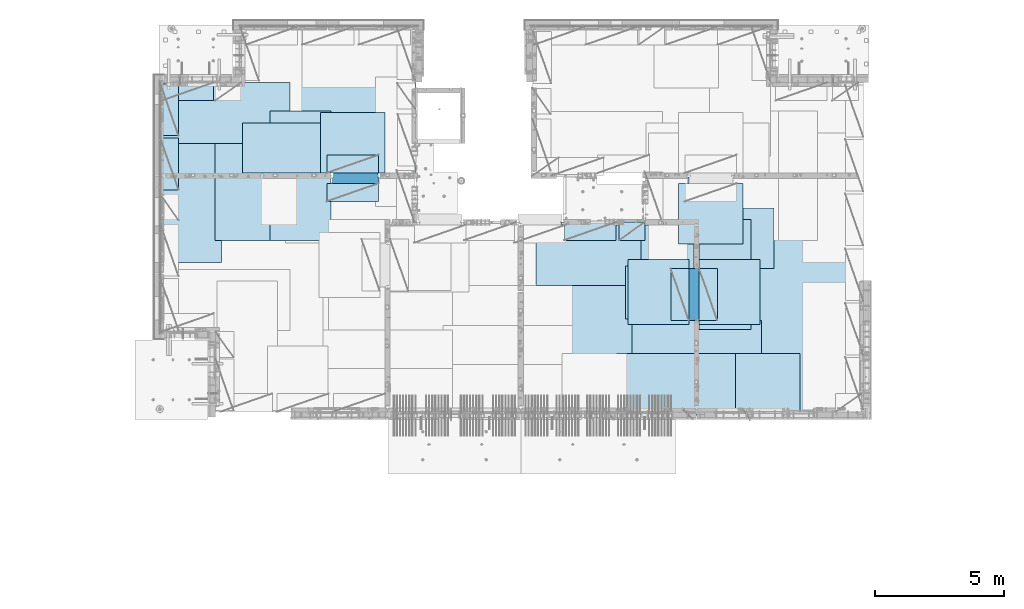
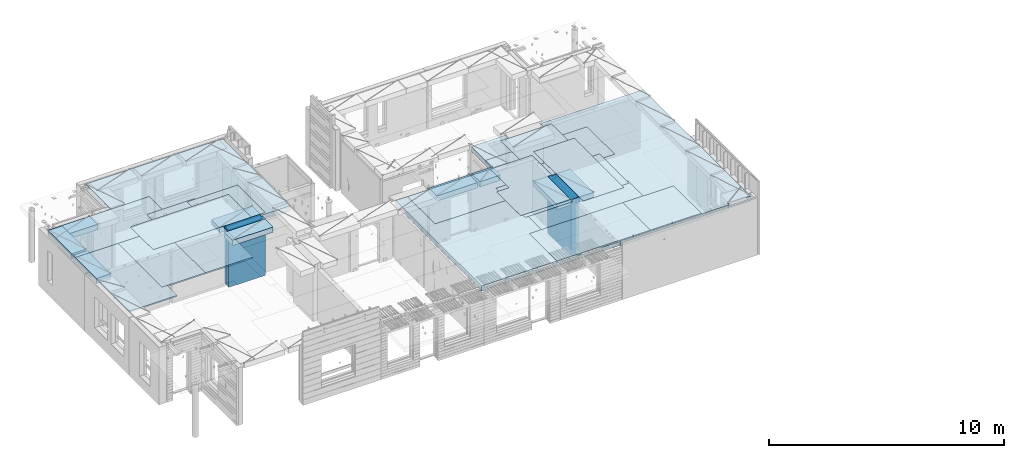
# One storey, part 175 of 309: 27 plates, 3 slabs, 25 elements without a shape of their own.
"""IFC2X3 building model written with IfcOpenShell, lengths in millimetres."""

from ifc_helpers import new_model, si_unit, frame, origin_with_axes, place, context, subcontext, project, spatial, faceted_brep, material, type_object, element, aggregate, save


model = new_model("IFC2X3")

# Units and contexts
model_context = context("Model", 3, precision=1e-05, world=origin_with_axes())
body_context = subcontext(model_context, "Body", "Model", "MODEL_VIEW")
ifc_project = project(units=[si_unit("LENGTHUNIT", "METRE", prefix="MILLI"), si_unit("AREAUNIT", "SQUARE_METRE"), si_unit("VOLUMEUNIT", "CUBIC_METRE"), si_unit("MASSUNIT", "GRAM", prefix="KILO"), si_unit("TIMEUNIT", "SECOND"), si_unit("PLANEANGLEUNIT", "RADIAN"), si_unit("SOLIDANGLEUNIT", "STERADIAN"), si_unit("THERMODYNAMICTEMPERATUREUNIT", "DEGREE_CELSIUS"), si_unit("LUMINOUSINTENSITYUNIT", "LUMEN")], contexts=[model_context])

# Site, building, storey
site_placement = place(None, origin_with_axes())
site = spatial("IfcSite", under=ifc_project, at=site_placement, CompositionType="ELEMENT")
building_placement = place(site_placement, origin_with_axes())
building = spatial("IfcBuilding", under=site, at=building_placement, CompositionType="ELEMENT")
storey_placement = place(building_placement, origin_with_axes())
storey = spatial("IfcBuildingStorey", under=building, at=storey_placement, Name="7", CompositionType="ELEMENT", Elevation=0.0)

# Assembly, slabs
assembly_1_placement = place(storey_placement, origin_with_axes())
assembly_1 = element("IfcElementAssembly", 1, at=assembly_1_placement, inside=storey, AssemblyPlace="NOTDEFINED", PredefinedType="REINFORCEMENT_UNIT")
ifc_material_1 = material(Name="CONCRETE/C30/37")
slab_type_1 = type_object("IfcSlabType", PredefinedType="NOTDEFINED")
slab_1_placement = place(assembly_1_placement, frame((21810.0, 7750.0, 102595.0), z_axis=(0.0, 1.0, 0.0), x_axis=(1.0, 0.0, 0.0)))
slab_1 = element("IfcSlab", 2, at=slab_1_placement, type_object=slab_type_1, material=ifc_material_1, PredefinedType="FLOOR", context=body_context, shape_type="Brep", body=[
    faceted_brep([(6500.0, -135.0, 5637.99963378906), (6500.0, 135.0, 5637.99963378906), (6500.0, 135.0, 5680.0), (6500.0, -135.0, 5680.0), (6800.0, -135.0, 5680.0), (6800.0, 135.0, 5680.0), (6800.0, -135.0, 3637.99963378906), (6800.0, 135.0, 3637.99963378906), (6500.0, 135.0, 3637.99963378906), (6500.0, -135.0, 3637.99963378906), (6800.0, -135.0, 0.0), (6800.0, 135.0, 0.0), (1.81898940354586e-12, -135.0, 1.81898940354586e-12), (1.81898940354586e-12, 135.0, 1.81898940354586e-12), (0.0, -135.0, 7330.0), (0.0, 135.0, 7330.0), (1569.99914550782, -135.0, 7330.0), (1569.99914550782, 135.0, 7330.0), (1569.99914550782, -135.0, 7430.0), (1569.99914550782, 135.0, 7430.0), (6800.0, -135.0, 7430.0), (6800.0, 135.0, 7430.0), (6500.0, 135.0, 3780.0), (6500.0, -135.0, 3780.0)], [[[0, 1, 2, 3]], [[4, 3, 2, 5]], [[6, 7, 8, 9]], [[10, 11, 7, 6]], [[10, 12, 13, 11]], [[12, 14, 15, 13]], [[16, 17, 15, 14]], [[18, 19, 17, 16]], [[20, 21, 19, 18]], [[21, 20, 4, 5]], [[1, 22, 8, 7, 11, 13, 15, 17, 19, 21, 5, 2]], [[23, 9, 8, 22, 1, 0]], [[20, 18, 16, 14, 12, 10, 6, 9, 23, 0, 3, 4]]]),
])
slab_type_2 = type_object("IfcSlabType", PredefinedType="NOTDEFINED")
slab_2_placement = place(assembly_1_placement, frame((7880.0, 16980.0, 102595.0), z_axis=(0.0, 1.0, 0.0), x_axis=(1.0, 0.0, 0.0)))
slab_2 = element("IfcSlab", 3, at=slab_2_placement, type_object=slab_type_2, material=ifc_material_1, PredefinedType="FLOOR", context=body_context, shape_type="Brep", body=[
    faceted_brep([(6583.68914550781, -135.0, 0.0), (6583.68914550781, 135.0, 0.0), (6583.68914550781, 135.0, 100.0), (6583.68914550781, -135.0, 100.0), (6649.99914550781, -135.0, 99.9997787475586), (6649.99914550781, 135.0, 99.9997787475586), (1.81898940354586e-12, -135.0, 1.81898940354586e-12), (-0.0001220703125, -135.0, 3600.0), (-0.0001220703125, 135.0, 3600.0), (1.81898940354586e-12, 135.0, 1.81898940354586e-12), (3110.00024414063, -135.0, 3600.0), (3110.00024414063, 135.0, 3600.0), (3110.00024414063, -135.0, 5760.0), (3110.00024414063, 135.0, 5760.0), (9850.0009765625, -135.0, 5760.0), (9850.0009765625, 135.0, 5760.0), (9850.0009765625, -135.0, 3600.0), (9850.0009765625, 135.0, 3600.0), (9870.0, -135.0, 3600.0), (9870.0, 135.0, 3600.0), (9870.0, -135.0, 0.0), (9870.0, 135.0, 0.0), (8449.99914550781, -135.0, 0.0), (8449.99914550781, 135.0, 0.0), (8449.99914550781, -135.0, 99.9997787475586), (8449.99914550781, 135.0, 99.9997787475586), (8283.68914550781, -135.0, 99.9997787475586), (8283.68914550781, 135.0, 99.9997787475586)], [[[0, 1, 2, 3]], [[4, 3, 2, 5]], [[6, 7, 8, 9]], [[7, 10, 11, 8]], [[10, 12, 13, 11]], [[12, 14, 15, 13]], [[14, 16, 17, 15]], [[16, 18, 19, 17]], [[18, 20, 21, 19]], [[21, 20, 22, 23]], [[24, 25, 23, 22]], [[26, 4, 5, 27, 25, 24]], [[1, 9, 8, 11, 13, 15, 17, 19, 21, 23, 25, 27, 5, 2]], [[6, 9, 1, 0]], [[26, 24, 22, 20, 18, 16, 14, 12, 10, 7, 6, 0, 3, 4]]]),
])
slab_type_3 = type_object("IfcSlabType", PredefinedType="NOTDEFINED")
slab_3_placement = place(assembly_1_placement, frame((28610.0, 7708.0, 102595.0), z_axis=(0.0, 1.0, 0.0), x_axis=(1.0, 0.0, 0.0)))
slab_3 = element("IfcSlab", 4, at=slab_3_placement, type_object=slab_type_3, material=ifc_material_1, PredefinedType="FLOOR", context=body_context, shape_type="Brep", body=[
    faceted_brep([(0.0, -135.0, 7430.0), (0.0, 135.0, 7430.0), (0.0, 135.0, 5722.0), (0.0, -135.0, 5722.0), (-1999.99938964844, -135.0, 7430.0), (-1999.99938964844, 135.0, 7430.0), (-1999.99938964844, -135.0, 9230.0), (-1999.99938964844, 135.0, 9230.0), (-300.000239723071, -135.0, 9230.0), (-300.000239723071, 135.0, 9230.0), (-300.00008947117, -135.0, 8972.00002930513), (-300.00008947117, 135.0, 8972.00002930513), (1385.00027673977, -135.0, 8972.00002930513), (1400.0006429507, -135.0, 8972.00002930513), (1400.0006429507, 135.0, 8972.00002930513), (1385.00027673977, 135.0, 8972.00002930513), (1400.0006429507, -135.0, 9230.0), (1400.0006429507, 135.0, 9230.0), (6449.99951171875, -135.0, 9230.0), (6449.99951171875, 135.0, 9230.0), (6449.99951171875, -135.0, 100.00023651123), (6449.99951171875, 135.0, 100.00023651123), (5318.0, -135.0, 100.0), (5318.0, 135.0, 100.0), (5318.0, -135.0, -8.68840288603678e-09), (5318.0, 135.0, -8.68840288603678e-09), (1.81898940354586e-12, -135.0, 1.81898940354586e-12), (1.81898940354586e-12, 135.0, 1.81898940354586e-12), (0.0, 135.0, 3679.99963378906), (100.00089263916, 135.0, 3679.99963378906), (100.00089263916, 135.0, 3822.0), (100.00089263916, 135.0, 5679.99963378906), (100.00089263916, 135.0, 5722.0), (100.00089263916, -135.0, 5722.0), (100.00089263916, -135.0, 3822.0), (100.00089263916, -135.0, 3679.99963378906), (0.0, -135.0, 3679.99963378906), (100.00089263916, -135.0, 5679.99963378906)], [[[0, 1, 2, 3]], [[0, 4, 5, 1]], [[4, 6, 7, 5]], [[7, 6, 8, 9]], [[8, 10, 11, 9]], [[12, 13, 14, 15, 11, 10]], [[16, 17, 14, 13]], [[18, 19, 17, 16]], [[18, 20, 21, 19]], [[20, 22, 23, 21]], [[22, 24, 25, 23]], [[24, 26, 27, 25]], [[1, 5, 7, 9, 11, 15, 14, 17, 19, 21, 23, 25, 27, 28, 29, 30, 31, 32, 2]], [[3, 2, 32, 33]], [[34, 35, 36, 26, 24, 22, 20, 18, 16, 13, 12, 10, 8, 6, 4, 0, 3, 33, 37]], [[27, 26, 36, 28]], [[35, 29, 28, 36]], [[34, 37, 31, 30, 29, 35]], [[33, 32, 31, 37]]]),
])

# Assembly, plate
assembly_2_placement = place(storey_placement, origin_with_axes())
assembly_2 = element("IfcElementAssembly", 5, at=assembly_2_placement, inside=storey, Name="Steel Assembly", AssemblyPlace="NOTDEFINED", PredefinedType="NOTDEFINED")
ifc_material_2 = material()
plate_type_1 = type_object("IfcPlateType", PredefinedType="NOTDEFINED")
plate_1_placement = place(assembly_2_placement, frame((27902.5000293051, 16680.0, 102695.1), z_axis=(1.0, 0.0, 0.0), x_axis=(0.0, -1.0, 0.0)))
plate_1 = element("IfcPlate", 6, at=plate_1_placement, type_object=plate_type_1, material=ifc_material_2, Name="1/2", context=body_context, shape_type="Brep", body=[
    faceted_brep([(0.0, -35.0, 0.0), (0.0, -35.0, 2500.0), (0.0, 35.0, 2500.0), (0.0, 35.0, 0.0), (2349.99951171875, -35.0, 2500.0), (2349.99951171875, 35.0, 2500.0), (2350.0, -35.0, 0.0), (2350.0, 35.0, 0.0)], [[[0, 1, 2, 3]], [[1, 4, 5, 2]], [[4, 6, 7, 5]], [[6, 0, 3, 7]], [[5, 7, 3, 2]], [[6, 4, 1, 0]]]),
])
aggregate(assembly_2, [plate_1])

assembly_3_placement = place(storey_placement, origin_with_axes())
assembly_3 = element("IfcElementAssembly", 7, at=assembly_3_placement, inside=storey, Name="Steel Assembly", AssemblyPlace="NOTDEFINED", PredefinedType="NOTDEFINED")
plate_2_placement = place(assembly_3_placement, frame((32610.0, 7750.0, 102695.1), z_axis=(-1.0, 3.00000001838171e-08, 0.0), x_axis=(0.0, 1.0, 0.0)))
plate_2 = element("IfcPlate", 8, at=plate_2_placement, type_object=plate_type_1, material=ifc_material_2, Name="1/2", context=body_context, shape_type="Brep", body=[
    faceted_brep([(0.0, -35.0, 0.0), (0.0, -35.0, 2500.0), (0.0, 35.0, 2500.0), (0.0, 35.0, 0.0), (2349.99951171875, -35.0, 2500.0), (2349.99951171875, 35.0, 2500.0), (2350.0, -35.0, 0.0), (2350.0, 35.0, 0.0)], [[[0, 1, 2, 3]], [[1, 4, 5, 2]], [[4, 6, 7, 5]], [[6, 0, 3, 7]], [[5, 7, 3, 2]], [[6, 4, 1, 0]]]),
])
aggregate(assembly_3, [plate_2])

assembly_4_placement = place(storey_placement, origin_with_axes())
assembly_4 = element("IfcElementAssembly", 9, at=assembly_4_placement, inside=storey, Name="Steel Assembly", AssemblyPlace="NOTDEFINED", PredefinedType="NOTDEFINED")
plate_3_placement = place(assembly_4_placement, frame((27395.0, 12730.0, 102695.1), z_axis=(-1.0, 3.00000001838171e-08, 0.0), x_axis=(0.0, 1.0, 0.0)))
plate_3 = element("IfcPlate", 10, at=plate_3_placement, type_object=plate_type_1, material=ifc_material_2, context=body_context, shape_type="Brep", body=[
    faceted_brep([(0.0, -35.0, 0.0), (0.0, -35.0, 5000.0), (0.0, 35.0, 5000.0), (0.0, 35.0, 0.0), (2349.99951171875, -35.0, 5000.0), (2349.99951171875, 35.0, 5000.0), (2350.0, -35.0, 0.0), (2350.0, 35.0, 0.0)], [[[0, 1, 2, 3]], [[1, 4, 5, 2]], [[4, 6, 7, 5]], [[6, 0, 3, 7]], [[5, 7, 3, 2]], [[6, 4, 1, 0]]]),
])
aggregate(assembly_4, [plate_3])

assembly_5_placement = place(storey_placement, origin_with_axes())
assembly_5 = element("IfcElementAssembly", 11, at=assembly_5_placement, inside=storey, Name="Steel Assembly", AssemblyPlace="NOTDEFINED", PredefinedType="NOTDEFINED")
plate_4_placement = place(assembly_5_placement, frame((28709.9995320312, 11230.0000289158, 102695.1), z_axis=(0.0, 1.0, 0.0), x_axis=(1.0, 0.0, 0.0)))
plate_4 = element("IfcPlate", 12, at=plate_4_placement, type_object=plate_type_1, material=ifc_material_2, Name="1/2", context=body_context, shape_type="Brep", body=[
    faceted_brep([(0.0, -35.0, 0.0), (0.0, -35.0, 2500.0), (0.0, 35.0, 2500.0), (0.0, 35.0, 0.0), (2349.99951171875, -35.0, 2500.0), (2349.99951171875, 35.0, 2500.0), (2350.0, -35.0, 0.0), (2350.0, 35.0, 0.0)], [[[0, 1, 2, 3]], [[1, 4, 5, 2]], [[4, 6, 7, 5]], [[6, 0, 3, 7]], [[5, 7, 3, 2]], [[6, 4, 1, 0]]]),
])
aggregate(assembly_5, [plate_4])

assembly_6_placement = place(storey_placement, origin_with_axes())
assembly_6 = element("IfcElementAssembly", 13, at=assembly_6_placement, inside=storey, Name="Steel Assembly", AssemblyPlace="NOTDEFINED", PredefinedType="NOTDEFINED")
plate_5_placement = place(assembly_6_placement, frame((25959.9995320312, 11230.0000289158, 102695.1), z_axis=(0.0, 1.0, 0.0), x_axis=(1.0, 0.0, 0.0)))
plate_5 = element("IfcPlate", 14, at=plate_5_placement, type_object=plate_type_1, material=ifc_material_2, Name="1/2", context=body_context, shape_type="Brep", body=[
    faceted_brep([(0.0, -35.0, 0.0), (0.0, -35.0, 2500.0), (0.0, 35.0, 2500.0), (0.0, 35.0, 0.0), (2349.99951171875, -35.0, 2500.0), (2349.99951171875, 35.0, 2500.0), (2350.0, -35.0, 0.0), (2350.0, 35.0, 0.0)], [[[0, 1, 2, 3]], [[1, 4, 5, 2]], [[4, 6, 7, 5]], [[6, 0, 3, 7]], [[5, 7, 3, 2]], [[6, 4, 1, 0]]]),
])
aggregate(assembly_6, [plate_5])

assembly_7_placement = place(storey_placement, origin_with_axes())
assembly_7 = element("IfcElementAssembly", 15, at=assembly_7_placement, inside=storey, Name="Steel Assembly", AssemblyPlace="NOTDEFINED", PredefinedType="NOTDEFINED")
plate_6_placement = place(assembly_7_placement, frame((7880.0, 20580.0, 102695.1), z_axis=(1.0, 0.0, 0.0), x_axis=(0.0, -1.0, 0.0)))
plate_6 = element("IfcPlate", 16, at=plate_6_placement, type_object=plate_type_1, material=ifc_material_2, context=body_context, shape_type="Brep", body=[
    faceted_brep([(0.0, -35.0, 0.0), (0.0, -35.0, 5000.0), (0.0, 35.0, 5000.0), (0.0, 35.0, 0.0), (2349.99951171875, -35.0, 5000.0), (2349.99951171875, 35.0, 5000.0), (2350.0, -35.0, 0.0), (2350.0, 35.0, 0.0)], [[[0, 1, 2, 3]], [[1, 4, 5, 2]], [[4, 6, 7, 5]], [[6, 0, 3, 7]], [[5, 7, 3, 2]], [[6, 4, 1, 0]]]),
])
aggregate(assembly_7, [plate_6])

assembly_8_placement = place(storey_placement, origin_with_axes())
assembly_8 = element("IfcElementAssembly", 17, at=assembly_8_placement, inside=storey, Name="Steel Assembly", AssemblyPlace="NOTDEFINED", PredefinedType="NOTDEFINED")
plate_7_placement = place(assembly_8_placement, frame((14063.69, 19430.0, 102695.1), z_axis=(1.0, 0.0, 0.0), x_axis=(0.0, -1.0, 0.0)))
plate_7 = element("IfcPlate", 18, at=plate_7_placement, type_object=plate_type_1, material=ifc_material_2, Name="1/2", context=body_context, shape_type="Brep", body=[
    faceted_brep([(0.0, -35.0, 0.0), (0.0, -35.0, 2500.0), (0.0, 35.0, 2500.0), (0.0, 35.0, 0.0), (2349.99951171875, -35.0, 2500.0), (2349.99951171875, 35.0, 2500.0), (2350.0, -35.0, 0.0), (2350.0, 35.0, 0.0)], [[[0, 1, 2, 3]], [[1, 4, 5, 2]], [[4, 6, 7, 5]], [[6, 0, 3, 7]], [[5, 7, 3, 2]], [[6, 4, 1, 0]]]),
])
aggregate(assembly_8, [plate_7])

assembly_9_placement = place(storey_placement, origin_with_axes())
assembly_9 = element("IfcElementAssembly", 19, at=assembly_9_placement, inside=storey, Name="Steel Assembly", AssemblyPlace="NOTDEFINED", PredefinedType="NOTDEFINED")
plate_8_placement = place(assembly_9_placement, frame((31610.0, 13388.0, 102695.1), z_axis=(-1.0, 3.00000001838171e-08, 0.0), x_axis=(0.0, 1.0, 0.0)))
plate_8 = element("IfcPlate", 20, at=plate_8_placement, type_object=plate_type_1, material=ifc_material_2, context=body_context, shape_type="Brep", body=[
    faceted_brep([(0.0, -35.0, 0.0), (0.0, -35.0, 5000.0), (0.0, 35.0, 5000.0), (0.0, 35.0, 0.0), (2349.99951171875, -35.0, 5000.0), (2349.99951171875, 35.0, 5000.0), (2350.0, -35.0, 0.0), (2350.0, 35.0, 0.0)], [[[0, 1, 2, 3]], [[1, 4, 5, 2]], [[4, 6, 7, 5]], [[6, 0, 3, 7]], [[5, 7, 3, 2]], [[6, 4, 1, 0]]]),
])
aggregate(assembly_9, [plate_8])

assembly_10_placement = place(storey_placement, origin_with_axes())
assembly_10 = element("IfcElementAssembly", 21, at=assembly_10_placement, inside=storey, Name="Steel Assembly", AssemblyPlace="NOTDEFINED", PredefinedType="NOTDEFINED")
plate_9_placement = place(assembly_10_placement, frame((31110.0, 9038.0, 102695.1), z_axis=(-1.0, 3.00000001838171e-08, 0.0), x_axis=(0.0, 1.0, 0.0)))
plate_9 = element("IfcPlate", 22, at=plate_9_placement, type_object=plate_type_1, material=ifc_material_2, context=body_context, shape_type="Brep", body=[
    faceted_brep([(0.0, -35.0, 0.0), (0.0, -35.0, 5000.0), (0.0, 35.0, 5000.0), (0.0, 35.0, 0.0), (2349.99951171875, -35.0, 5000.0), (2349.99951171875, 35.0, 5000.0), (2350.0, -35.0, 0.0), (2350.0, 35.0, 0.0)], [[[0, 1, 2, 3]], [[1, 4, 5, 2]], [[4, 6, 7, 5]], [[6, 0, 3, 7]], [[5, 7, 3, 2]], [[6, 4, 1, 0]]]),
])
aggregate(assembly_10, [plate_9])

assembly_11_placement = place(storey_placement, origin_with_axes())
assembly_11 = element("IfcElementAssembly", 23, at=assembly_11_placement, inside=storey, Name="Steel Assembly", AssemblyPlace="NOTDEFINED", PredefinedType="NOTDEFINED")
plate_10_placement = place(assembly_11_placement, frame((30510.0, 7750.0, 102695.1), z_axis=(-1.0, 3.00000001838171e-08, 0.0), x_axis=(0.0, 1.0, 0.0)))
plate_10 = element("IfcPlate", 24, at=plate_10_placement, type_object=plate_type_1, material=ifc_material_2, context=body_context, shape_type="Brep", body=[
    faceted_brep([(0.0, -35.0, 0.0), (0.0, -35.0, 5000.0), (0.0, 35.0, 5000.0), (0.0, 35.0, 0.0), (2349.99951171875, -35.0, 5000.0), (2349.99951171875, 35.0, 5000.0), (2350.0, -35.0, 0.0), (2350.0, 35.0, 0.0)], [[[0, 1, 2, 3]], [[1, 4, 5, 2]], [[4, 6, 7, 5]], [[6, 0, 3, 7]], [[5, 7, 3, 2]], [[6, 4, 1, 0]]]),
])
aggregate(assembly_11, [plate_10])

assembly_12_placement = place(storey_placement, origin_with_axes())
assembly_12 = element("IfcElementAssembly", 25, at=assembly_12_placement, inside=storey, Name="Steel Assembly", AssemblyPlace="NOTDEFINED", PredefinedType="NOTDEFINED")
plate_11_placement = place(assembly_12_placement, frame((10230.0, 18627.0, 102695.1), z_axis=(0.0, -1.0, 0.0), x_axis=(-1.0, 3.00000001838171e-08, 0.0)))
plate_11 = element("IfcPlate", 26, at=plate_11_placement, type_object=plate_type_1, material=ifc_material_2, context=body_context, shape_type="Brep", body=[
    faceted_brep([(0.0, -35.0, 0.0), (0.0, -35.0, 5000.0), (0.0, 35.0, 5000.0), (0.0, 35.0, 0.0), (2349.99951171875, -35.0, 5000.0), (2349.99951171875, 35.0, 5000.0), (2350.0, -35.0, 0.0), (2350.0, 35.0, 0.0)], [[[0, 1, 2, 3]], [[1, 4, 5, 2]], [[4, 6, 7, 5]], [[6, 0, 3, 7]], [[5, 7, 3, 2]], [[6, 4, 1, 0]]]),
])
aggregate(assembly_12, [plate_11])

assembly_13_placement = place(storey_placement, origin_with_axes())
assembly_13 = element("IfcElementAssembly", 27, at=assembly_13_placement, inside=storey, Name="Steel Assembly", AssemblyPlace="NOTDEFINED", PredefinedType="NOTDEFINED")
plate_12_placement = place(assembly_13_placement, frame((14463.69, 19480.0, 102695.1), z_axis=(0.0, -1.0, 0.0), x_axis=(-1.0, 3.00000001838171e-08, 0.0)))
plate_12 = element("IfcPlate", 28, at=plate_12_placement, type_object=plate_type_1, material=ifc_material_2, context=body_context, shape_type="Brep", body=[
    faceted_brep([(0.0, -35.0, 0.0), (0.0, -35.0, 5000.0), (0.0, 35.0, 5000.0), (0.0, 35.0, 0.0), (2349.99951171875, -35.0, 5000.0), (2349.99951171875, 35.0, 5000.0), (2350.0, -35.0, 0.0), (2350.0, 35.0, 0.0)], [[[0, 1, 2, 3]], [[1, 4, 5, 2]], [[4, 6, 7, 5]], [[6, 0, 3, 7]], [[5, 7, 3, 2]], [[6, 4, 1, 0]]]),
])
aggregate(assembly_13, [plate_12])

assembly_14_placement = place(storey_placement, origin_with_axes())
assembly_14 = element("IfcElementAssembly", 29, at=assembly_14_placement, inside=storey, Name="Steel Assembly", AssemblyPlace="NOTDEFINED", PredefinedType="NOTDEFINED")
plate_13_placement = place(assembly_14_placement, frame((12330.0, 19480.0, 102695.1), z_axis=(0.0, -1.0, 0.0), x_axis=(-1.0, 3.00000001838171e-08, 0.0)))
plate_13 = element("IfcPlate", 30, at=plate_13_placement, type_object=plate_type_1, material=ifc_material_2, context=body_context, shape_type="Brep", body=[
    faceted_brep([(0.0, -35.0, 0.0), (0.0, -35.0, 5000.0), (0.0, 35.0, 5000.0), (0.0, 35.0, 0.0), (2349.99951171875, -35.0, 5000.0), (2349.99951171875, 35.0, 5000.0), (2350.0, -35.0, 0.0), (2350.0, 35.0, 0.0)], [[[0, 1, 2, 3]], [[1, 4, 5, 2]], [[4, 6, 7, 5]], [[6, 0, 3, 7]], [[5, 7, 3, 2]], [[6, 4, 1, 0]]]),
])
aggregate(assembly_14, [plate_13])

assembly_15_placement = place(storey_placement, origin_with_axes())
assembly_15 = element("IfcElementAssembly", 31, at=assembly_15_placement, inside=storey, Name="Steel Assembly", AssemblyPlace="NOTDEFINED", PredefinedType="NOTDEFINED")
plate_type_2 = type_object("IfcPlateType", PredefinedType="NOTDEFINED")
plate_14_placement = place(assembly_15_placement, frame((7879.99987792969, 20530.0, 102595.3), z_axis=(1.0, 0.0, 0.0), x_axis=(0.0, -1.0, 0.0)))
plate_14 = element("IfcPlate", 32, at=plate_14_placement, type_object=plate_type_2, material=ifc_material_2, Name="RE1", context=body_context, shape_type="Brep", body=[
    faceted_brep([(1.81898940354586e-12, -135.0, 1.81898940354586e-12), (0.0, -135.0, 699.999999999996), (0.0, 135.0, 699.999999999996), (1.81898940354586e-12, 135.0, 1.81898940354586e-12), (1999.99951171875, -135.0, 699.999999999993), (1999.99951171875, 135.0, 699.999999999993), (2000.0, -135.0, -3.63797880709171e-12), (2000.0, 135.0, -3.63797880709171e-12)], [[[0, 1, 2, 3]], [[1, 4, 5, 2]], [[4, 6, 7, 5]], [[6, 0, 3, 7]], [[5, 7, 3, 2]], [[6, 4, 1, 0]]]),
])
aggregate(assembly_15, [plate_14])

assembly_16_placement = place(storey_placement, origin_with_axes())
assembly_16 = element("IfcElementAssembly", 33, at=assembly_16_placement, inside=storey, Name="Steel Assembly", AssemblyPlace="NOTDEFINED", PredefinedType="NOTDEFINED")
plate_15_placement = place(assembly_16_placement, frame((28710.2298779297, 13388.0, 102595.3), z_axis=(1.0, 0.0, 0.0), x_axis=(0.0, -1.0, 0.0)))
plate_15 = element("IfcPlate", 34, at=plate_15_placement, type_object=plate_type_2, material=ifc_material_2, Name="RE1", context=body_context, shape_type="Brep", body=[
    faceted_brep([(1.81898940354586e-12, -135.0, 1.81898940354586e-12), (0.0, -135.0, 699.999999999996), (0.0, 135.0, 699.999999999996), (1.81898940354586e-12, 135.0, 1.81898940354586e-12), (1999.99951171875, -135.0, 699.999999999993), (1999.99951171875, 135.0, 699.999999999993), (2000.0, -135.0, -3.63797880709171e-12), (2000.0, 135.0, -3.63797880709171e-12)], [[[0, 1, 2, 3]], [[1, 4, 5, 2]], [[4, 6, 7, 5]], [[6, 0, 3, 7]], [[5, 7, 3, 2]], [[6, 4, 1, 0]]]),
])
aggregate(assembly_16, [plate_15])

assembly_17_placement = place(storey_placement, origin_with_axes())
assembly_17 = element("IfcElementAssembly", 35, at=assembly_17_placement, inside=storey, Name="Steel Assembly", AssemblyPlace="NOTDEFINED", PredefinedType="NOTDEFINED")
plate_16_placement = place(assembly_17_placement, frame((28310.0001220703, 11388.0, 102595.3), z_axis=(-1.0, 3.00000001838171e-08, 0.0), x_axis=(0.0, 1.0, 0.0)))
plate_16 = element("IfcPlate", 36, at=plate_16_placement, type_object=plate_type_2, material=ifc_material_2, Name="RE1", context=body_context, shape_type="Brep", body=[
    faceted_brep([(1.81898940354586e-12, -135.0, 1.81898940354586e-12), (0.0, -135.0, 699.999999999996), (0.0, 135.0, 699.999999999996), (1.81898940354586e-12, 135.0, 1.81898940354586e-12), (1999.99951171875, -135.0, 699.999999999993), (1999.99951171875, 135.0, 699.999999999993), (2000.0, -135.0, -3.63797880709171e-12), (2000.0, 135.0, -3.63797880709171e-12)], [[[0, 1, 2, 3]], [[1, 4, 5, 2]], [[4, 6, 7, 5]], [[6, 0, 3, 7]], [[5, 7, 3, 2]], [[6, 4, 1, 0]]]),
])
aggregate(assembly_17, [plate_16])

assembly_18_placement = place(storey_placement, origin_with_axes())
assembly_18 = element("IfcElementAssembly", 37, at=assembly_18_placement, inside=storey, Name="Steel Assembly", AssemblyPlace="NOTDEFINED", PredefinedType="NOTDEFINED")
plate_17_placement = place(assembly_18_placement, frame((14313.6908542386, 17080.0001036336, 102595.3), z_axis=(0.0, 1.0, 0.0), x_axis=(1.0, 0.0, 0.0)))
plate_17 = element("IfcPlate", 38, at=plate_17_placement, type_object=plate_type_2, material=ifc_material_2, Name="RE1", context=body_context, shape_type="Brep", body=[
    faceted_brep([(1.81898940354586e-12, -135.0, 1.81898940354586e-12), (0.0, -135.0, 699.999999999996), (0.0, 135.0, 699.999999999996), (1.81898940354586e-12, 135.0, 1.81898940354586e-12), (1999.99951171875, -135.0, 699.999999999993), (1999.99951171875, 135.0, 699.999999999993), (2000.0, -135.0, -3.63797880709171e-12), (2000.0, 135.0, -3.63797880709171e-12)], [[[0, 1, 2, 3]], [[1, 4, 5, 2]], [[4, 6, 7, 5]], [[6, 0, 3, 7]], [[5, 7, 3, 2]], [[6, 4, 1, 0]]]),
])
aggregate(assembly_18, [plate_17])

assembly_19_placement = place(storey_placement, origin_with_axes())
assembly_19 = element("IfcElementAssembly", 39, at=assembly_19_placement, inside=storey, Name="Steel Assembly", AssemblyPlace="NOTDEFINED", PredefinedType="NOTDEFINED")
plate_18_placement = place(assembly_19_placement, frame((16313.6891457614, 16679.9998963664, 102595.3), z_axis=(0.0, -1.0, 0.0), x_axis=(-1.0, 3.00000001838171e-08, 0.0)))
plate_18 = element("IfcPlate", 40, at=plate_18_placement, type_object=plate_type_2, material=ifc_material_2, Name="RE1", context=body_context, shape_type="Brep", body=[
    faceted_brep([(1.81898940354586e-12, -135.0, 1.81898940354586e-12), (0.0, -135.0, 699.999999999996), (0.0, 135.0, 699.999999999996), (1.81898940354586e-12, 135.0, 1.81898940354586e-12), (1999.99951171875, -135.0, 699.999999999993), (1999.99951171875, 135.0, 699.999999999993), (2000.0, -135.0, -3.63797880709171e-12), (2000.0, 135.0, -3.63797880709171e-12)], [[[0, 1, 2, 3]], [[1, 4, 5, 2]], [[4, 6, 7, 5]], [[6, 0, 3, 7]], [[5, 7, 3, 2]], [[6, 4, 1, 0]]]),
])
aggregate(assembly_19, [plate_18])

assembly_20_placement = place(storey_placement, origin_with_axes())
assembly_20 = element("IfcElementAssembly", 41, at=assembly_20_placement, inside=storey, Name="Steel Assembly", AssemblyPlace="NOTDEFINED", PredefinedType="NOTDEFINED")
plate_19_placement = place(assembly_20_placement, frame((25494.9991457614, 15179.9998963664, 102595.3), z_axis=(0.0, -1.0, 0.0), x_axis=(-1.0, 3.00000001838171e-08, 0.0)))
plate_19 = element("IfcPlate", 42, at=plate_19_placement, type_object=plate_type_2, material=ifc_material_2, Name="RE1", context=body_context, shape_type="Brep", body=[
    faceted_brep([(1.81898940354586e-12, -135.0, 1.81898940354586e-12), (0.0, -135.0, 699.999999999996), (0.0, 135.0, 699.999999999996), (1.81898940354586e-12, 135.0, 1.81898940354586e-12), (1999.99951171875, -135.0, 699.999999999993), (1999.99951171875, 135.0, 699.999999999993), (2000.0, -135.0, -3.63797880709171e-12), (2000.0, 135.0, -3.63797880709171e-12)], [[[0, 1, 2, 3]], [[1, 4, 5, 2]], [[4, 6, 7, 5]], [[6, 0, 3, 7]], [[5, 7, 3, 2]], [[6, 4, 1, 0]]]),
])
aggregate(assembly_20, [plate_19])

assembly_21_placement = place(storey_placement, origin_with_axes())
assembly_21 = element("IfcElementAssembly", 43, at=assembly_21_placement, inside=storey, Name="Steel Assembly", AssemblyPlace="NOTDEFINED", PredefinedType="NOTDEFINED")
plate_20_placement = place(assembly_21_placement, frame((26610.0, 15180.0000000707, 102595.3), z_axis=(0.0, -1.0, 0.0), x_axis=(-1.0, 3.00000001838171e-08, 0.0)))
plate_20 = element("IfcPlate", 44, at=plate_20_placement, type_object=plate_type_2, material=ifc_material_2, Name="RE1_1/2", context=body_context, shape_type="Brep", body=[
    faceted_brep([(1.81898940354586e-12, -135.0, 1.81898940354586e-12), (0.0, -135.0, 699.999999999996), (0.0, 135.0, 699.999999999996), (1.81898940354586e-12, 135.0, 1.81898940354586e-12), (999.99951171875, -135.0, 700.0), (999.99951171875, 135.0, 700.0), (1000.0, -135.0, 0.0), (1000.0, 135.0, 0.0)], [[[0, 1, 2, 3]], [[1, 4, 5, 2]], [[4, 6, 7, 5]], [[6, 0, 3, 7]], [[5, 7, 3, 2]], [[6, 4, 1, 0]]]),
])
aggregate(assembly_21, [plate_20])

assembly_22_placement = place(storey_placement, origin_with_axes())
assembly_22 = element("IfcElementAssembly", 45, at=assembly_22_placement, inside=storey, Name="Steel Assembly", AssemblyPlace="NOTDEFINED", PredefinedType="NOTDEFINED")
plate_21_placement = place(assembly_22_placement, frame((9935.0, 20580.0001220703, 102595.3), z_axis=(0.0, -1.0, 0.0), x_axis=(-1.0, 3.00000001838171e-08, 0.0)))
plate_21 = element("IfcPlate", 46, at=plate_21_placement, type_object=plate_type_2, material=ifc_material_2, Name="RE1", context=body_context, shape_type="Brep", body=[
    faceted_brep([(1.81898940354586e-12, -135.0, 1.81898940354586e-12), (0.0, -135.0, 699.999999999996), (0.0, 135.0, 699.999999999996), (1.81898940354586e-12, 135.0, 1.81898940354586e-12), (1999.99951171875, -135.0, 699.999999999993), (1999.99951171875, 135.0, 699.999999999993), (2000.0, -135.0, -3.63797880709171e-12), (2000.0, 135.0, -3.63797880709171e-12)], [[[0, 1, 2, 3]], [[1, 4, 5, 2]], [[4, 6, 7, 5]], [[6, 0, 3, 7]], [[5, 7, 3, 2]], [[6, 4, 1, 0]]]),
])
aggregate(assembly_22, [plate_21])

assembly_23_placement = place(storey_placement, origin_with_axes())
assembly_23 = element("IfcElementAssembly", 47, at=assembly_23_placement, inside=storey, Name="Steel Assembly", AssemblyPlace="NOTDEFINED", PredefinedType="NOTDEFINED")
plate_22_placement = place(assembly_23_placement, frame((7879.99987792969, 18430.0, 102595.3), z_axis=(1.0, 0.0, 0.0), x_axis=(0.0, -1.0, 0.0)))
plate_22 = element("IfcPlate", 48, at=plate_22_placement, type_object=plate_type_2, material=ifc_material_2, Name="RE1", context=body_context, shape_type="Brep", body=[
    faceted_brep([(1.81898940354586e-12, -135.0, 1.81898940354586e-12), (0.0, -135.0, 699.999999999996), (0.0, 135.0, 699.999999999996), (1.81898940354586e-12, 135.0, 1.81898940354586e-12), (1999.99951171875, -135.0, 699.999999999993), (1999.99951171875, 135.0, 699.999999999993), (2000.0, -135.0, -3.63797880709171e-12), (2000.0, 135.0, -3.63797880709171e-12)], [[[0, 1, 2, 3]], [[1, 4, 5, 2]], [[4, 6, 7, 5]], [[6, 0, 3, 7]], [[5, 7, 3, 2]], [[6, 4, 1, 0]]]),
])
aggregate(assembly_23, [plate_22])

# Plate
plate_type_3 = type_object("IfcPlateType", PredefinedType="NOTDEFINED")
plate_23_placement = place(assembly_1_placement, frame((11048.0003525539, 17079.9997757405, 102725.45), z_axis=(0.0, 1.0, 0.0), x_axis=(1.0, 0.0, 0.0)))
plate_23 = element("IfcPlate", 49, at=plate_23_placement, type_object=plate_type_3, material=ifc_material_2, context=body_context, shape_type="Brep", body=[
    faceted_brep([(0.0, -5.0, 0.0), (0.0, -5.0, 1939.99963378906), (0.0, 5.0, 1939.99963378906), (0.0, 5.0, 0.0), (4827.9990234375, -5.0, 1939.99963378906), (4827.9990234375, 5.0, 1939.99963378906), (4827.9990234375, -5.0, 0.0), (4827.9990234375, 5.0, 0.0)], [[[0, 1, 2, 3]], [[1, 4, 5, 2]], [[4, 6, 7, 5]], [[6, 0, 3, 7]], [[5, 7, 3, 2]], [[6, 4, 1, 0]]]),
])

plate_type_4 = type_object("IfcPlateType", PredefinedType="NOTDEFINED")
plate_24_placement = place(assembly_1_placement, frame((28710.0010086818, 11039.9998138874, 102725.45), z_axis=(0.0, 1.0, 0.0), x_axis=(1.0, 0.0, 0.0)))
plate_24 = element("IfcPlate", 50, at=plate_24_placement, type_object=plate_type_4, material=ifc_material_2, context=body_context, shape_type="Brep", body=[
    faceted_brep([(0.0, -5.0, 0.0), (-0.00100868183653802, -5.0, 4240.0), (-0.00100868183653802, 5.0, 4240.0), (0.0, 5.0, 0.0), (2000.0, -5.0, 4240.0), (2000.0, 5.0, 4240.0), (2000.0, -5.0, 0.0), (2000.0, 5.0, 0.0)], [[[0, 1, 2, 3]], [[1, 4, 5, 2]], [[4, 6, 7, 5]], [[6, 0, 3, 7]], [[5, 7, 3, 2]], [[6, 4, 1, 0]]]),
])

plate_type_5 = type_object("IfcPlateType", PredefinedType="NOTDEFINED")
plate_25_placement = place(assembly_1_placement, frame((25860.0006272121, 11525.9998749226, 102725.45), z_axis=(1.0, 0.0, 0.0), x_axis=(0.0, -1.0, 0.0)))
plate_25 = element("IfcPlate", 51, at=plate_25_placement, type_object=plate_type_5, material=ifc_material_2, context=body_context, shape_type="Brep", body=[
    faceted_brep([(92.0000076293945, -5.0, 2449.99937278789), (92.0000076293945, 5.0, 2449.99937278789), (-1861.99975886647, 5.0, 2449.99937278789), (-1861.99975886647, -5.0, 2449.99937278789), (-1861.99975886647, -5.0, 2649.99937278789), (-1861.99975886647, 5.0, 2649.99939842034), (92.0000076293945, -5.0, 0.0), (0.0, -5.0, 0.0), (0.0, 5.0, 0.0), (92.0000076293945, 5.0, 0.0), (-1954.00048828125, -5.0, 0.0), (-1954.00048828125, 5.0, 0.0), (-1954.00048828125, -5.0, 600.000366210938), (-1954.00048828125, 5.0, 600.000366210938), (-3554.0, -5.0, 600.000366210938), (-3554.0, 5.0, 600.000366210938), (-3554.0, -5.0, 2649.99951171875), (-3554.0, 5.0, 2649.99951171875)], [[[0, 1, 2, 3]], [[4, 3, 2, 5]], [[6, 7, 8, 9]], [[7, 10, 11, 8]], [[10, 12, 13, 11]], [[12, 14, 15, 13]], [[14, 16, 17, 15]], [[17, 16, 4, 5]], [[1, 9, 8, 11, 13, 15, 17, 5, 2]], [[6, 9, 1, 0]], [[16, 14, 12, 10, 7, 6, 0, 3, 4]]]),
])

aggregate(assembly_1, [plate_24, plate_25, plate_23, slab_3, slab_1, slab_2])

# Assembly, plate
assembly_24_placement = place(storey_placement, origin_with_axes())
assembly_24 = element("IfcElementAssembly", 52, at=assembly_24_placement, inside=storey, Name="Steel Assembly", AssemblyPlace="NOTDEFINED", PredefinedType="NOTDEFINED")
ifc_material_3 = material()
plate_type_6 = type_object("IfcPlateType", PredefinedType="NOTDEFINED")
plate_26_placement = place(assembly_24_placement, frame((14530.0, 16680.0, 101255.600000381), z_axis=(0.0, 1.0, 0.0), x_axis=(1.0, 0.0, 0.0)))
plate_26 = element("IfcPlate", 53, at=plate_26_placement, type_object=plate_type_6, material=ifc_material_3, context=body_context, shape_type="Brep", body=[
    faceted_brep([(1749.99914550781, -1475.0, 400.0), (1749.99914550781, -1475.0, 243.000000000004), (1749.99914550781, 1475.0, 243.000000000004), (1749.99914550781, 1475.0, 400.0), (1799.99914550781, -1475.0, 221.333333333332), (1799.99914550781, 1475.0, 221.333333333332), (30.0, -1475.0, 400.0), (30.0, 1475.0, 400.0), (30.0, 1475.0, 243.0), (30.0, -1475.0, 243.0), (0.0, 1475.0, 230.0), (0.0, -1475.0, 230.0), (0.0, 1475.0, 0.0), (0.0, -1475.0, 0.0), (1799.99914550781, -1475.0, 3.63797880709171e-12), (1799.99914550781, 1475.0, 3.63797880709171e-12)], [[[0, 1, 2, 3]], [[4, 5, 2, 1]], [[6, 7, 8, 9]], [[9, 8, 10, 11]], [[12, 13, 11, 10]], [[14, 13, 12, 15]], [[0, 6, 9, 11, 13, 14, 4, 1]], [[7, 6, 0, 3]], [[15, 12, 10, 8, 7, 3, 2, 5]], [[14, 15, 5, 4]]]),
])
aggregate(assembly_24, [plate_26])

assembly_25_placement = place(storey_placement, origin_with_axes())
assembly_25 = element("IfcElementAssembly", 54, at=assembly_25_placement, inside=storey, Name="Steel Assembly", AssemblyPlace="NOTDEFINED", PredefinedType="NOTDEFINED")
plate_27_placement = place(assembly_25_placement, frame((28710.0, 11388.0, 101255.600000381), z_axis=(-1.0, 3.00000001838171e-08, 0.0), x_axis=(0.0, 1.0, 0.0)))
plate_27 = element("IfcPlate", 55, at=plate_27_placement, type_object=plate_type_6, material=ifc_material_3, context=body_context, shape_type="Brep", body=[
    faceted_brep([(0.0, -1475.0, 170.000000230655), (0.0, 1475.0, 170.000000368096), (30.0, 1475.0, 156.999999999998), (30.0, -1475.0, 156.999999999998), (29.9999998430139, -1475.0, 0.0), (29.9999998430139, 1475.0, 0.0), (0.0, -1475.0, 400.0), (1999.99963378906, -1475.0, 400.0), (1999.99963378906, 1475.0, 400.0), (0.0, 1475.0, 400.0), (1999.99963378906, -1475.0, 170.000003831468), (1999.99963378906, 1475.0, 170.000003831468), (1969.99962494722, -1475.0, 157.0), (1969.99962494722, 1475.0, 157.0), (1969.99962494722, -1475.0, 0.0), (1969.99962494722, 1475.0, 0.0)], [[[0, 1, 2, 3]], [[4, 3, 2, 5]], [[6, 7, 8, 9]], [[8, 7, 10, 11]], [[12, 13, 11, 10]], [[14, 15, 13, 12]], [[15, 14, 4, 5]], [[1, 9, 8, 11, 13, 15, 5, 2]], [[6, 9, 1, 0]], [[14, 12, 10, 7, 6, 0, 3, 4]]]),
])
aggregate(assembly_25, [plate_27])

save(model, "model.ifc")
